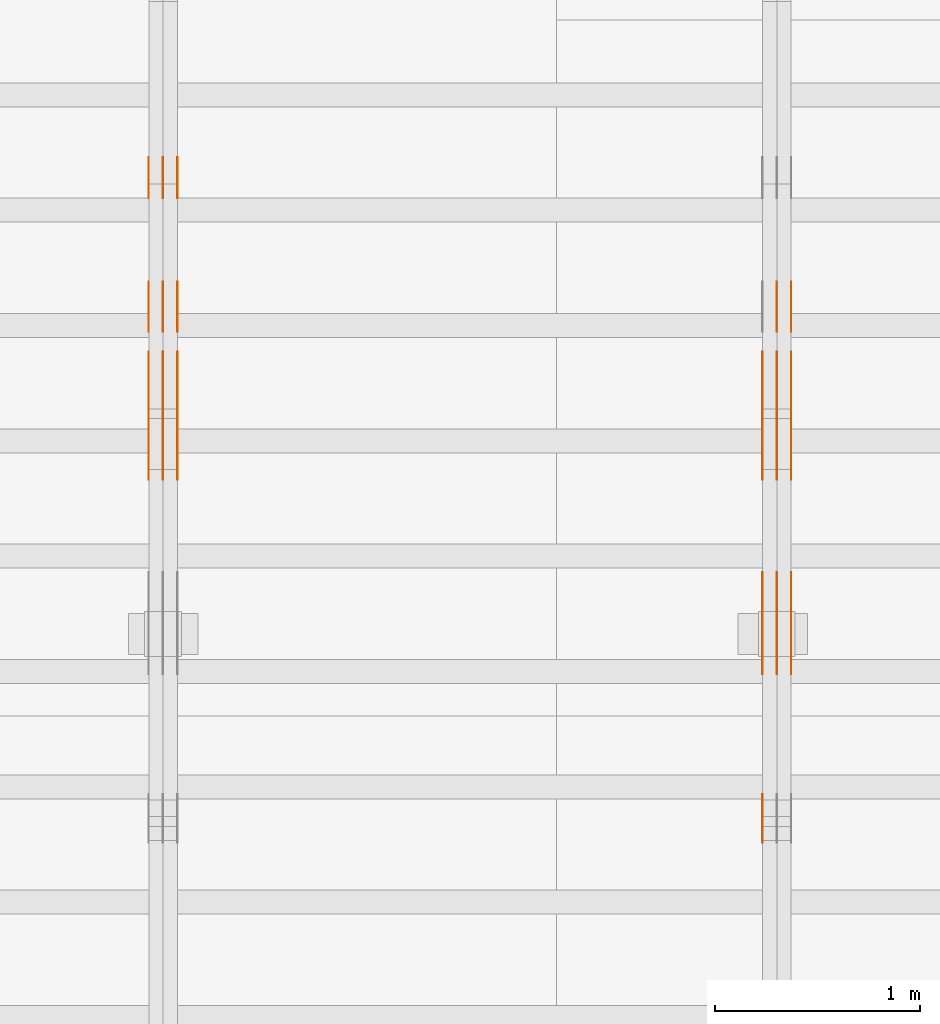
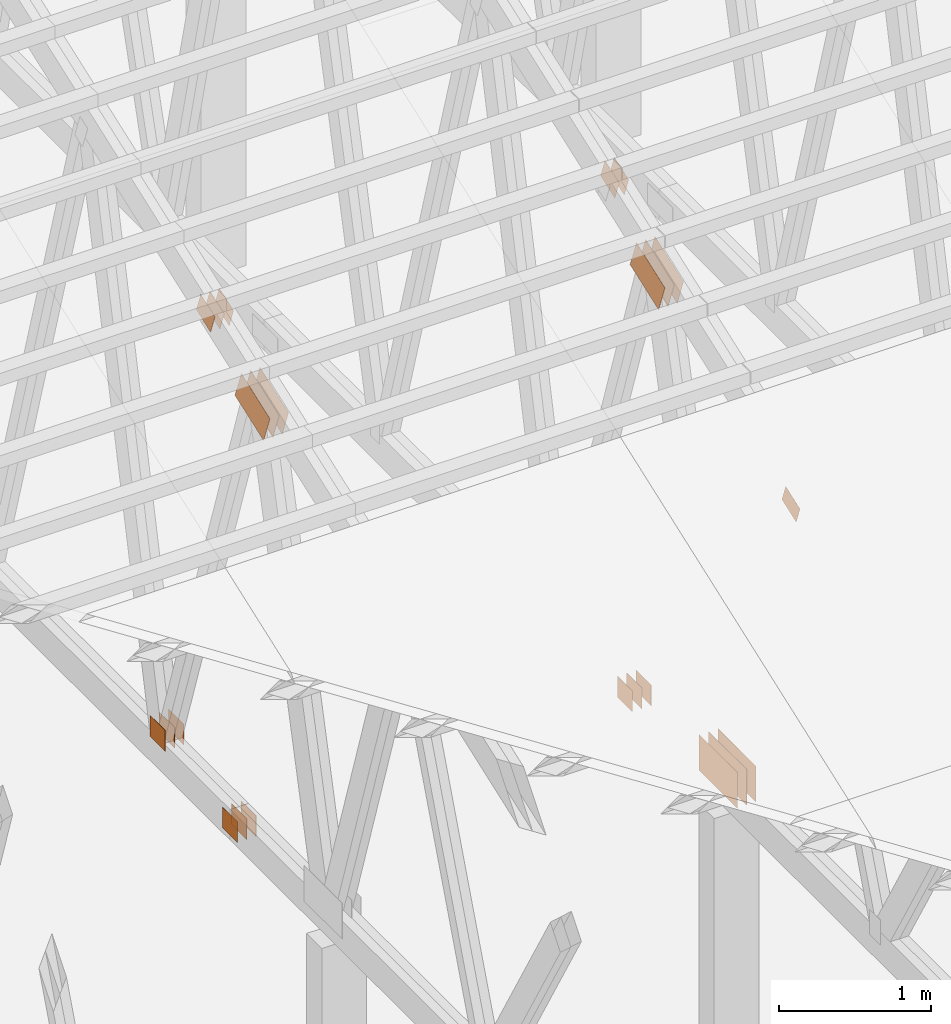
# One storey, part 101 of 189: 31 proxies.
"""IFC2X3 building model written with IfcOpenShell, lengths in millimetres."""

from ifc_helpers import new_model, entity, si_unit, converted_unit, derived_unit, direction, frame, frame_2d, origin, origin_2d_with_axis, place, context, subcontext, project, spatial, polyline, rectangle, outline, extrude, source, transform, mapped, material, type_object, type_shapes, element, save


model = new_model("IFC2X3")

# Units and contexts
model_context = context("Model", 3, precision=0.01, world=origin(), true_north=direction((6.12303176911189e-17, 1.0)))
body_context = subcontext(model_context, "Body", "Model", "MODEL_VIEW")
ifc_project = project(units=[si_unit("LENGTHUNIT", "METRE", prefix="MILLI"), si_unit("AREAUNIT", "SQUARE_METRE"), si_unit("VOLUMEUNIT", "CUBIC_METRE"), converted_unit("PLANEANGLEUNIT", "DEGREE", entity("IfcRatioMeasure", 0.0174532925199433), si_unit("PLANEANGLEUNIT", "RADIAN"), dimensions=[0, 0, 0, 0, 0, 0, 0]), si_unit("MASSUNIT", "GRAM", prefix="KILO"), derived_unit("MASSDENSITYUNIT", [(si_unit("MASSUNIT", "GRAM", prefix="KILO"), 1), (si_unit("LENGTHUNIT", "METRE"), -3)]), si_unit("TIMEUNIT", "SECOND"), si_unit("FREQUENCYUNIT", "HERTZ"), si_unit("THERMODYNAMICTEMPERATUREUNIT", "DEGREE_CELSIUS"), derived_unit("THERMALTRANSMITTANCEUNIT", [(si_unit("MASSUNIT", "GRAM", prefix="KILO"), 1), (si_unit("THERMODYNAMICTEMPERATUREUNIT", "KELVIN"), -1), (si_unit("TIMEUNIT", "SECOND"), -3)]), derived_unit("VOLUMETRICFLOWRATEUNIT", [(si_unit("LENGTHUNIT", "METRE"), 3), (si_unit("TIMEUNIT", "SECOND"), -1)]), si_unit("ELECTRICCURRENTUNIT", "AMPERE"), si_unit("ELECTRICVOLTAGEUNIT", "VOLT"), si_unit("POWERUNIT", "WATT"), si_unit("FORCEUNIT", "NEWTON"), si_unit("ILLUMINANCEUNIT", "LUX"), si_unit("LUMINOUSFLUXUNIT", "LUMEN"), si_unit("LUMINOUSINTENSITYUNIT", "CANDELA"), derived_unit("USERDEFINED", [(si_unit("MASSUNIT", "GRAM", prefix="KILO"), -1), (si_unit("LENGTHUNIT", "METRE"), -2), (si_unit("TIMEUNIT", "SECOND"), 3), (si_unit("LUMINOUSFLUXUNIT", "LUMEN"), 1)]), derived_unit("LINEARVELOCITYUNIT", [(si_unit("LENGTHUNIT", "METRE"), 1), (si_unit("TIMEUNIT", "SECOND"), -1)]), si_unit("PRESSUREUNIT", "PASCAL"), derived_unit("USERDEFINED", [(si_unit("LENGTHUNIT", "METRE"), -2), (si_unit("MASSUNIT", "GRAM", prefix="KILO"), 1), (si_unit("TIMEUNIT", "SECOND"), -2)])], contexts=[model_context])

# Site, building, storey
site_placement = place(None, origin())
site = spatial("IfcSite", under=ifc_project, at=site_placement, CompositionType="ELEMENT")
building_placement = place(site_placement, origin())
building = spatial("IfcBuilding", under=site, at=building_placement, CompositionType="ELEMENT")
storey_placement = place(building_placement, origin())
storey = spatial("IfcBuildingStorey", under=building, at=storey_placement, Name="Default", CompositionType="ELEMENT", Elevation=0.0)

# Proxies
ifc_material_1 = material(Name="IfcSurfaceStyle #171462")
building_element_proxy_type_1 = type_object("IfcBuildingElementProxyType", PredefinedType="NOTDEFINED", material=ifc_material_1)
shared_shape_1 = source(origin(), body_context, "Body", "SweptSolid", [
    extrude(outline(polyline([(-199.999582244654, -119.99984375717), (200.000344770932, -119.99984375717), (199.999582244655, 119.99984375717), (-200.000344770934, 119.99984375717), (-199.999582244654, -119.99984375717)])), frame((200.000344770932, 120.0000091947, 0.0), z_axis=(0.0, 0.0, 1.0), x_axis=(-1.0, 0.0, 0.0)), (0.0, 0.0, 1.0), 1.29999999999999),
])
type_shapes(building_element_proxy_type_1, [shared_shape_1])
proxy_1_placement = place(building_placement, frame((30301.3, 9961.90704972973, 3612.2451494258), z_axis=(-1.0, 0.0, 0.0), x_axis=(0.0, -0.939692620785908, -0.342020143325669)))
element("IfcBuildingElementProxy", 1, at=proxy_1_placement, inside=storey, type_object=building_element_proxy_type_1, material=ifc_material_1, context=body_context, shape_type="MappedRepresentation", body=[
    mapped(shared_shape_1, transform((0.0, 0.0, 0.0), scale=1.0)),
])
ifc_material_2 = material(Name="IfcSurfaceStyle #171405")
building_element_proxy_type_2 = type_object("IfcBuildingElementProxyType", PredefinedType="NOTDEFINED", material=ifc_material_2)
shared_shape_2 = source(origin(), body_context, "Body", "SweptSolid", [
    extrude(outline(polyline([(-199.999582244654, -119.99984375717), (200.000344770932, -119.99984375717), (199.999582244655, 119.99984375717), (-200.000344770934, 119.99984375717), (-199.999582244654, -119.99984375717)])), frame((200.000344770932, 120.0000091947, 0.0), z_axis=(0.0, 0.0, 1.0), x_axis=(-1.0, 0.0, 0.0)), (0.0, 0.0, 1.0), 1.29999999999997),
])
type_shapes(building_element_proxy_type_2, [shared_shape_2])
proxy_2_placement = place(building_placement, frame((30230.0, 9961.90704972973, 3612.2451494258), z_axis=(-1.0, 0.0, 0.0), x_axis=(0.0, -0.939692620785908, -0.342020143325669)))
element("IfcBuildingElementProxy", 2, at=proxy_2_placement, inside=storey, type_object=building_element_proxy_type_2, material=ifc_material_2, context=body_context, shape_type="MappedRepresentation", body=[
    mapped(shared_shape_2, transform((0.0, 0.0, 0.0), scale=1.0)),
])
ifc_material_3 = material(Name="IfcSurfaceStyle #171348")
building_element_proxy_type_3 = type_object("IfcBuildingElementProxyType", PredefinedType="NOTDEFINED", material=ifc_material_3)
shared_shape_3 = source(origin(), body_context, "Body", "SweptSolid", [
    extrude(outline(polyline([(-199.999582244654, -119.99984375717), (200.000344770932, -119.99984375717), (199.999582244655, 119.99984375717), (-200.000344770934, 119.99984375717), (-199.999582244654, -119.99984375717)])), frame((200.000344770932, 120.0000091947, 0.0), z_axis=(0.0, 0.0, 1.0), x_axis=(-1.0, 0.0, 0.0)), (0.0, 0.0, 1.0), 1.29999999999997),
])
type_shapes(building_element_proxy_type_3, [shared_shape_3])
proxy_3_placement = place(building_placement, frame((30231.3, 9961.90704972973, 3612.2451494258), z_axis=(-1.0, 0.0, 0.0), x_axis=(0.0, -0.939692620785908, -0.342020143325669)))
element("IfcBuildingElementProxy", 3, at=proxy_3_placement, inside=storey, type_object=building_element_proxy_type_3, material=ifc_material_3, context=body_context, shape_type="MappedRepresentation", body=[
    mapped(shared_shape_3, transform((0.0, 0.0, 0.0), scale=1.0)),
])
ifc_material_4 = material(Name="IfcSurfaceStyle #171291")
building_element_proxy_type_4 = type_object("IfcBuildingElementProxyType", PredefinedType="NOTDEFINED", material=ifc_material_4)
shared_shape_4 = source(origin(), body_context, "Body", "SweptSolid", [
    extrude(outline(polyline([(-199.999582244654, -119.99984375717), (200.000344770932, -119.99984375717), (199.999582244655, 119.99984375717), (-200.000344770934, 119.99984375717), (-199.999582244654, -119.99984375717)])), frame((200.000344770932, 120.0000091947, 0.0), z_axis=(0.0, 0.0, 1.0), x_axis=(-1.0, 0.0, 0.0)), (0.0, 0.0, 1.0), 1.29999999999998),
])
type_shapes(building_element_proxy_type_4, [shared_shape_4])
proxy_4_placement = place(building_placement, frame((30160.0, 9961.90704972973, 3612.2451494258), z_axis=(-1.0, 0.0, 0.0), x_axis=(0.0, -0.939692620785908, -0.342020143325669)))
element("IfcBuildingElementProxy", 4, at=proxy_4_placement, inside=storey, type_object=building_element_proxy_type_4, material=ifc_material_4, context=body_context, shape_type="MappedRepresentation", body=[
    mapped(shared_shape_4, transform((0.0, 0.0, 0.0), scale=1.0)),
])
ifc_material_5 = material(Name="IfcSurfaceStyle #170778")
building_element_proxy_type_5 = type_object("IfcBuildingElementProxyType", PredefinedType="NOTDEFINED", material=ifc_material_5)
shared_shape_5 = source(origin(), body_context, "Body", "SweptSolid", [
    extrude(rectangle(XDim=500.0, YDim=288.0, at=frame_2d((0.0, 1.4210854715202e-14), x_axis=(1.0, 0.0))), frame((250.000973740011, 144.0, 0.0), z_axis=(0.0, 0.0, 1.0), x_axis=(-1.0, 0.0, 0.0)), (0.0, 0.0, 1.0), 1.29999999999998),
])
type_shapes(building_element_proxy_type_5, [shared_shape_5])
proxy_5_placement = place(building_placement, frame((30301.3, 8551.90918250999, 389.0), z_axis=(-1.0, 0.0, 0.0), x_axis=(0.0, 1.0, 0.0)))
element("IfcBuildingElementProxy", 5, at=proxy_5_placement, inside=storey, type_object=building_element_proxy_type_5, material=ifc_material_5, context=body_context, shape_type="MappedRepresentation", body=[
    mapped(shared_shape_5, transform((0.0, 0.0, 0.0), scale=1.0)),
])
ifc_material_6 = material(Name="IfcSurfaceStyle #170721")
building_element_proxy_type_6 = type_object("IfcBuildingElementProxyType", PredefinedType="NOTDEFINED", material=ifc_material_6)
shared_shape_6 = source(origin(), body_context, "Body", "SweptSolid", [
    extrude(rectangle(XDim=500.0, YDim=288.0, at=frame_2d((0.0, 1.4210854715202e-14), x_axis=(1.0, 0.0))), frame((250.000973740011, 144.0, 0.0), z_axis=(0.0, 0.0, 1.0), x_axis=(-1.0, 0.0, 0.0)), (0.0, 0.0, 1.0), 1.29999999999997),
])
type_shapes(building_element_proxy_type_6, [shared_shape_6])
proxy_6_placement = place(building_placement, frame((30230.0, 8551.90918250999, 389.0), z_axis=(-1.0, 0.0, 0.0), x_axis=(0.0, 1.0, 0.0)))
element("IfcBuildingElementProxy", 6, at=proxy_6_placement, inside=storey, type_object=building_element_proxy_type_6, material=ifc_material_6, context=body_context, shape_type="MappedRepresentation", body=[
    mapped(shared_shape_6, transform((0.0, 0.0, 0.0), scale=1.0)),
])
ifc_material_7 = material(Name="IfcSurfaceStyle #170664")
building_element_proxy_type_7 = type_object("IfcBuildingElementProxyType", PredefinedType="NOTDEFINED", material=ifc_material_7)
shared_shape_7 = source(origin(), body_context, "Body", "SweptSolid", [
    extrude(rectangle(XDim=500.0, YDim=288.0, at=frame_2d((0.0, 1.4210854715202e-14), x_axis=(1.0, 0.0))), frame((250.000973740011, 144.0, 0.0), z_axis=(0.0, 0.0, 1.0), x_axis=(-1.0, 0.0, 0.0)), (0.0, 0.0, 1.0), 1.29999999999997),
])
type_shapes(building_element_proxy_type_7, [shared_shape_7])
proxy_7_placement = place(building_placement, frame((30231.3, 8551.90918250999, 389.0), z_axis=(-1.0, 0.0, 0.0), x_axis=(0.0, 1.0, 0.0)))
element("IfcBuildingElementProxy", 7, at=proxy_7_placement, inside=storey, type_object=building_element_proxy_type_7, material=ifc_material_7, context=body_context, shape_type="MappedRepresentation", body=[
    mapped(shared_shape_7, transform((0.0, 0.0, 0.0), scale=1.0)),
])
ifc_material_8 = material(Name="IfcSurfaceStyle #170607")
building_element_proxy_type_8 = type_object("IfcBuildingElementProxyType", PredefinedType="NOTDEFINED", material=ifc_material_8)
shared_shape_8 = source(origin(), body_context, "Body", "SweptSolid", [
    extrude(rectangle(XDim=500.0, YDim=288.0, at=frame_2d((0.0, 1.4210854715202e-14), x_axis=(1.0, 0.0))), frame((250.000973740011, 144.0, 0.0), z_axis=(0.0, 0.0, 1.0), x_axis=(-1.0, 0.0, 0.0)), (0.0, 0.0, 1.0), 1.29999999999997),
])
type_shapes(building_element_proxy_type_8, [shared_shape_8])
proxy_8_placement = place(building_placement, frame((30160.0, 8551.90918250999, 389.0), z_axis=(-1.0, 0.0, 0.0), x_axis=(0.0, 1.0, 0.0)))
element("IfcBuildingElementProxy", 8, at=proxy_8_placement, inside=storey, type_object=building_element_proxy_type_8, material=ifc_material_8, context=body_context, shape_type="MappedRepresentation", body=[
    mapped(shared_shape_8, transform((0.0, 0.0, 0.0), scale=1.0)),
])
ifc_material_9 = material(Name="IfcSurfaceStyle #170379")
building_element_proxy_type_9 = type_object("IfcBuildingElementProxyType", PredefinedType="NOTDEFINED", material=ifc_material_9)
shared_shape_9 = source(origin(), body_context, "Body", "SweptSolid", [
    extrude(outline(polyline([(-100.00048713087, -72.0000025659129), (100.000394045495, -72.0000025659129), (99.9995694622958, 72.0000025659129), (-99.9994763769209, 72.0000025659128), (-100.00048713087, -72.0000025659129)])), frame((100.000394045495, 72.0000025659128, 0.0), z_axis=(0.0, 0.0, 1.0), x_axis=(-1.0, 0.0, 0.0)), (0.0, 0.0, 1.0), 1.29999999999999),
])
type_shapes(building_element_proxy_type_9, [shared_shape_9])
proxy_9_placement = place(building_placement, frame((30160.0, 7965.16887114408, 2936.19963864386), z_axis=(-1.0, 0.0, 0.0), x_axis=(0.0, -0.939692620785908, -0.342020143325669)))
element("IfcBuildingElementProxy", 9, at=proxy_9_placement, inside=storey, type_object=building_element_proxy_type_9, material=ifc_material_9, context=body_context, shape_type="MappedRepresentation", body=[
    mapped(shared_shape_9, transform((0.0, 0.0, 0.0), scale=1.0)),
])
ifc_material_10 = material(Name="IfcSurfaceStyle #165138")
building_element_proxy_type_10 = type_object("IfcBuildingElementProxyType", PredefinedType="NOTDEFINED", material=ifc_material_10)
shared_shape_10 = source(origin(), body_context, "Body", "SweptSolid", [
    extrude(rectangle(XDim=200.0, YDim=168.0, at=origin_2d_with_axis()), frame((100.0, 84.0, 0.0), z_axis=(0.0, 0.0, 1.0), x_axis=(-1.0, 0.0, 0.0)), (0.0, 0.0, 1.0), 1.3),
])
type_shapes(building_element_proxy_type_10, [shared_shape_10])
proxy_10_placement = place(building_placement, frame((30301.3, 9929.23046875, 206.5), z_axis=(-1.0, 0.0, 0.0), x_axis=(0.0, 1.0, 0.0)))
element("IfcBuildingElementProxy", 10, at=proxy_10_placement, inside=storey, type_object=building_element_proxy_type_10, material=ifc_material_10, context=body_context, shape_type="MappedRepresentation", body=[
    mapped(shared_shape_10, transform((0.0, 0.0, 0.0), scale=1.0)),
])
ifc_material_11 = material(Name="IfcSurfaceStyle #165081")
building_element_proxy_type_11 = type_object("IfcBuildingElementProxyType", PredefinedType="NOTDEFINED", material=ifc_material_11)
shared_shape_11 = source(origin(), body_context, "Body", "SweptSolid", [
    extrude(rectangle(XDim=200.0, YDim=168.0, at=origin_2d_with_axis()), frame((100.0, 84.0, 0.0), z_axis=(0.0, 0.0, 1.0), x_axis=(-1.0, 0.0, 0.0)), (0.0, 0.0, 1.0), 1.29999999999998),
])
type_shapes(building_element_proxy_type_11, [shared_shape_11])
proxy_11_placement = place(building_placement, frame((30230.0, 9929.23046875, 206.5), z_axis=(-1.0, 0.0, 0.0), x_axis=(0.0, 1.0, 0.0)))
element("IfcBuildingElementProxy", 11, at=proxy_11_placement, inside=storey, type_object=building_element_proxy_type_11, material=ifc_material_11, context=body_context, shape_type="MappedRepresentation", body=[
    mapped(shared_shape_11, transform((0.0, 0.0, 0.0), scale=1.0)),
])
ifc_material_12 = material(Name="IfcSurfaceStyle #165024")
building_element_proxy_type_12 = type_object("IfcBuildingElementProxyType", PredefinedType="NOTDEFINED", material=ifc_material_12)
shared_shape_12 = source(origin(), body_context, "Body", "SweptSolid", [
    extrude(rectangle(XDim=200.0, YDim=168.0, at=origin_2d_with_axis()), frame((100.0, 84.0, 0.0), z_axis=(0.0, 0.0, 1.0), x_axis=(-1.0, 0.0, 0.0)), (0.0, 0.0, 1.0), 1.29999999999998),
])
type_shapes(building_element_proxy_type_12, [shared_shape_12])
proxy_12_placement = place(building_placement, frame((30231.3, 9929.23046875, 206.5), z_axis=(-1.0, 0.0, 0.0), x_axis=(0.0, 1.0, 0.0)))
element("IfcBuildingElementProxy", 12, at=proxy_12_placement, inside=storey, type_object=building_element_proxy_type_12, material=ifc_material_12, context=body_context, shape_type="MappedRepresentation", body=[
    mapped(shared_shape_12, transform((0.0, 0.0, 0.0), scale=1.0)),
])
ifc_material_13 = material(Name="IfcSurfaceStyle #164967")
building_element_proxy_type_13 = type_object("IfcBuildingElementProxyType", PredefinedType="NOTDEFINED", material=ifc_material_13)
shared_shape_13 = source(origin(), body_context, "Body", "SweptSolid", [
    extrude(rectangle(XDim=200.0, YDim=168.0, at=origin_2d_with_axis()), frame((100.0, 84.0, 0.0), z_axis=(0.0, 0.0, 1.0), x_axis=(-1.0, 0.0, 0.0)), (0.0, 0.0, 1.0), 1.29999999999999),
])
type_shapes(building_element_proxy_type_13, [shared_shape_13])
proxy_13_placement = place(building_placement, frame((30160.0, 9929.23046875, 206.5), z_axis=(-1.0, 0.0, 0.0), x_axis=(0.0, 1.0, 0.0)))
element("IfcBuildingElementProxy", 13, at=proxy_13_placement, inside=storey, type_object=building_element_proxy_type_13, material=ifc_material_13, context=body_context, shape_type="MappedRepresentation", body=[
    mapped(shared_shape_13, transform((0.0, 0.0, 0.0), scale=1.0)),
])
ifc_material_14 = material(Name="IfcSurfaceStyle #164058")
building_element_proxy_type_14 = type_object("IfcBuildingElementProxyType", PredefinedType="NOTDEFINED", material=ifc_material_14)
shared_shape_14 = source(origin(), body_context, "Body", "SweptSolid", [
    extrude(outline(polyline([(-100.00072430513, -84.0000258989549), (100.000156871239, -84.0000258989549), (99.9997648860508, 84.0000258989549), (-99.9991974521591, 84.0000258989548), (-100.00072430513, -84.0000258989549)])), frame((100.000156871239, 84.0000258989548, 0.0), z_axis=(0.0, 0.0, 1.0), x_axis=(-1.0, 0.0, 0.0)), (0.0, 0.0, 1.0), 1.3),
])
type_shapes(building_element_proxy_type_14, [shared_shape_14])
proxy_14_placement = place(building_placement, frame((30301.3, 10226.4409888304, 4081.14941482552), z_axis=(-1.0, 0.0, 0.0), x_axis=(0.0, 0.939692620785908, 0.342020143325669)))
element("IfcBuildingElementProxy", 14, at=proxy_14_placement, inside=storey, type_object=building_element_proxy_type_14, material=ifc_material_14, context=body_context, shape_type="MappedRepresentation", body=[
    mapped(shared_shape_14, transform((0.0, 0.0, 0.0), scale=1.0)),
])
ifc_material_15 = material(Name="IfcSurfaceStyle #164001")
building_element_proxy_type_15 = type_object("IfcBuildingElementProxyType", PredefinedType="NOTDEFINED", material=ifc_material_15)
shared_shape_15 = source(origin(), body_context, "Body", "SweptSolid", [
    extrude(outline(polyline([(-100.00072430513, -84.0000258989549), (100.000156871239, -84.0000258989549), (99.9997648860508, 84.0000258989549), (-99.9991974521591, 84.0000258989548), (-100.00072430513, -84.0000258989549)])), frame((100.000156871239, 84.0000258989548, 0.0), z_axis=(0.0, 0.0, 1.0), x_axis=(-1.0, 0.0, 0.0)), (0.0, 0.0, 1.0), 1.29999999999998),
])
type_shapes(building_element_proxy_type_15, [shared_shape_15])
proxy_15_placement = place(building_placement, frame((30230.0, 10226.4409888304, 4081.14941482552), z_axis=(-1.0, 0.0, 0.0), x_axis=(0.0, 0.939692620785908, 0.342020143325669)))
element("IfcBuildingElementProxy", 15, at=proxy_15_placement, inside=storey, type_object=building_element_proxy_type_15, material=ifc_material_15, context=body_context, shape_type="MappedRepresentation", body=[
    mapped(shared_shape_15, transform((0.0, 0.0, 0.0), scale=1.0)),
])
ifc_material_16 = material(Name="IfcSurfaceStyle #155900")
building_element_proxy_type_16 = type_object("IfcBuildingElementProxyType", PredefinedType="NOTDEFINED", material=ifc_material_16)
shared_shape_16 = source(origin(), body_context, "Body", "SweptSolid", [
    extrude(rectangle(XDim=200.0, YDim=168.0, at=origin_2d_with_axis()), frame((100.000765376775, 84.0, 0.0), z_axis=(0.0, 0.0, 1.0), x_axis=(-1.0, 0.0, 0.0)), (0.0, 0.0, 1.0), 1.3),
])
type_shapes(building_element_proxy_type_16, [shared_shape_16])
proxy_16_placement = place(building_placement, frame((27301.3, 10880.1574377482, 365.0), z_axis=(-1.0, 0.0, 0.0), x_axis=(0.0, 1.0, 0.0)))
element("IfcBuildingElementProxy", 16, at=proxy_16_placement, inside=storey, type_object=building_element_proxy_type_16, material=ifc_material_16, context=body_context, shape_type="MappedRepresentation", body=[
    mapped(shared_shape_16, transform((0.0, 0.0, 0.0), scale=1.0)),
])
ifc_material_17 = material(Name="IfcSurfaceStyle #155843")
building_element_proxy_type_17 = type_object("IfcBuildingElementProxyType", PredefinedType="NOTDEFINED", material=ifc_material_17)
shared_shape_17 = source(origin(), body_context, "Body", "SweptSolid", [
    extrude(rectangle(XDim=200.0, YDim=168.0, at=origin_2d_with_axis()), frame((100.000765376775, 84.0, 0.0), z_axis=(0.0, 0.0, 1.0), x_axis=(-1.0, 0.0, 0.0)), (0.0, 0.0, 1.0), 1.29999999999998),
])
type_shapes(building_element_proxy_type_17, [shared_shape_17])
proxy_17_placement = place(building_placement, frame((27230.0, 10880.1574377482, 365.0), z_axis=(-1.0, 0.0, 0.0), x_axis=(0.0, 1.0, 0.0)))
element("IfcBuildingElementProxy", 17, at=proxy_17_placement, inside=storey, type_object=building_element_proxy_type_17, material=ifc_material_17, context=body_context, shape_type="MappedRepresentation", body=[
    mapped(shared_shape_17, transform((0.0, 0.0, 0.0), scale=1.0)),
])
ifc_material_18 = material(Name="IfcSurfaceStyle #155786")
building_element_proxy_type_18 = type_object("IfcBuildingElementProxyType", PredefinedType="NOTDEFINED", material=ifc_material_18)
shared_shape_18 = source(origin(), body_context, "Body", "SweptSolid", [
    extrude(rectangle(XDim=200.0, YDim=168.0, at=origin_2d_with_axis()), frame((100.000765376775, 84.0, 0.0), z_axis=(0.0, 0.0, 1.0), x_axis=(-1.0, 0.0, 0.0)), (0.0, 0.0, 1.0), 1.29999999999998),
])
type_shapes(building_element_proxy_type_18, [shared_shape_18])
proxy_18_placement = place(building_placement, frame((27231.3, 10880.1574377482, 365.0), z_axis=(-1.0, 0.0, 0.0), x_axis=(0.0, 1.0, 0.0)))
element("IfcBuildingElementProxy", 18, at=proxy_18_placement, inside=storey, type_object=building_element_proxy_type_18, material=ifc_material_18, context=body_context, shape_type="MappedRepresentation", body=[
    mapped(shared_shape_18, transform((0.0, 0.0, 0.0), scale=1.0)),
])
ifc_material_19 = material(Name="IfcSurfaceStyle #155729")
building_element_proxy_type_19 = type_object("IfcBuildingElementProxyType", PredefinedType="NOTDEFINED", material=ifc_material_19)
shared_shape_19 = source(origin(), body_context, "Body", "SweptSolid", [
    extrude(rectangle(XDim=200.0, YDim=168.0, at=origin_2d_with_axis()), frame((100.000765376775, 84.0, 0.0), z_axis=(0.0, 0.0, 1.0), x_axis=(-1.0, 0.0, 0.0)), (0.0, 0.0, 1.0), 1.29999999999999),
])
type_shapes(building_element_proxy_type_19, [shared_shape_19])
proxy_19_placement = place(building_placement, frame((27160.0, 10880.1574377482, 365.0), z_axis=(-1.0, 0.0, 0.0), x_axis=(0.0, 1.0, 0.0)))
element("IfcBuildingElementProxy", 19, at=proxy_19_placement, inside=storey, type_object=building_element_proxy_type_19, material=ifc_material_19, context=body_context, shape_type="MappedRepresentation", body=[
    mapped(shared_shape_19, transform((0.0, 0.0, 0.0), scale=1.0)),
])
ifc_material_20 = material(Name="IfcSurfaceStyle #155672")
building_element_proxy_type_20 = type_object("IfcBuildingElementProxyType", PredefinedType="NOTDEFINED", material=ifc_material_20)
shared_shape_20 = source(origin(), body_context, "Body", "SweptSolid", [
    extrude(outline(polyline([(-199.999582244654, -119.99984375717), (200.000344770932, -119.99984375717), (199.999582244655, 119.99984375717), (-200.000344770934, 119.99984375717), (-199.999582244654, -119.99984375717)])), frame((200.000344770932, 120.0000091947, 0.0), z_axis=(0.0, 0.0, 1.0), x_axis=(-1.0, 0.0, 0.0)), (0.0, 0.0, 1.0), 1.29999999999999),
])
type_shapes(building_element_proxy_type_20, [shared_shape_20])
proxy_20_placement = place(building_placement, frame((27301.3, 9961.90704972973, 3612.2451494258), z_axis=(-1.0, 0.0, 0.0), x_axis=(0.0, -0.939692620785908, -0.342020143325669)))
element("IfcBuildingElementProxy", 20, at=proxy_20_placement, inside=storey, type_object=building_element_proxy_type_20, material=ifc_material_20, context=body_context, shape_type="MappedRepresentation", body=[
    mapped(shared_shape_20, transform((0.0, 0.0, 0.0), scale=1.0)),
])
ifc_material_21 = material(Name="IfcSurfaceStyle #155615")
building_element_proxy_type_21 = type_object("IfcBuildingElementProxyType", PredefinedType="NOTDEFINED", material=ifc_material_21)
shared_shape_21 = source(origin(), body_context, "Body", "SweptSolid", [
    extrude(outline(polyline([(-199.999582244654, -119.99984375717), (200.000344770932, -119.99984375717), (199.999582244655, 119.99984375717), (-200.000344770934, 119.99984375717), (-199.999582244654, -119.99984375717)])), frame((200.000344770932, 120.0000091947, 0.0), z_axis=(0.0, 0.0, 1.0), x_axis=(-1.0, 0.0, 0.0)), (0.0, 0.0, 1.0), 1.29999999999997),
])
type_shapes(building_element_proxy_type_21, [shared_shape_21])
proxy_21_placement = place(building_placement, frame((27230.0, 9961.90704972973, 3612.2451494258), z_axis=(-1.0, 0.0, 0.0), x_axis=(0.0, -0.939692620785908, -0.342020143325669)))
element("IfcBuildingElementProxy", 21, at=proxy_21_placement, inside=storey, type_object=building_element_proxy_type_21, material=ifc_material_21, context=body_context, shape_type="MappedRepresentation", body=[
    mapped(shared_shape_21, transform((0.0, 0.0, 0.0), scale=1.0)),
])
ifc_material_22 = material(Name="IfcSurfaceStyle #155558")
building_element_proxy_type_22 = type_object("IfcBuildingElementProxyType", PredefinedType="NOTDEFINED", material=ifc_material_22)
shared_shape_22 = source(origin(), body_context, "Body", "SweptSolid", [
    extrude(outline(polyline([(-199.999582244654, -119.99984375717), (200.000344770932, -119.99984375717), (199.999582244655, 119.99984375717), (-200.000344770934, 119.99984375717), (-199.999582244654, -119.99984375717)])), frame((200.000344770932, 120.0000091947, 0.0), z_axis=(0.0, 0.0, 1.0), x_axis=(-1.0, 0.0, 0.0)), (0.0, 0.0, 1.0), 1.29999999999997),
])
type_shapes(building_element_proxy_type_22, [shared_shape_22])
proxy_22_placement = place(building_placement, frame((27231.3, 9961.90704972973, 3612.2451494258), z_axis=(-1.0, 0.0, 0.0), x_axis=(0.0, -0.939692620785908, -0.342020143325669)))
element("IfcBuildingElementProxy", 22, at=proxy_22_placement, inside=storey, type_object=building_element_proxy_type_22, material=ifc_material_22, context=body_context, shape_type="MappedRepresentation", body=[
    mapped(shared_shape_22, transform((0.0, 0.0, 0.0), scale=1.0)),
])
ifc_material_23 = material(Name="IfcSurfaceStyle #155501")
building_element_proxy_type_23 = type_object("IfcBuildingElementProxyType", PredefinedType="NOTDEFINED", material=ifc_material_23)
shared_shape_23 = source(origin(), body_context, "Body", "SweptSolid", [
    extrude(outline(polyline([(-199.999582244654, -119.99984375717), (200.000344770932, -119.99984375717), (199.999582244655, 119.99984375717), (-200.000344770934, 119.99984375717), (-199.999582244654, -119.99984375717)])), frame((200.000344770932, 120.0000091947, 0.0), z_axis=(0.0, 0.0, 1.0), x_axis=(-1.0, 0.0, 0.0)), (0.0, 0.0, 1.0), 1.29999999999998),
])
type_shapes(building_element_proxy_type_23, [shared_shape_23])
proxy_23_placement = place(building_placement, frame((27160.0, 9961.90704972973, 3612.2451494258), z_axis=(-1.0, 0.0, 0.0), x_axis=(0.0, -0.939692620785908, -0.342020143325669)))
element("IfcBuildingElementProxy", 23, at=proxy_23_placement, inside=storey, type_object=building_element_proxy_type_23, material=ifc_material_23, context=body_context, shape_type="MappedRepresentation", body=[
    mapped(shared_shape_23, transform((0.0, 0.0, 0.0), scale=1.0)),
])
ifc_material_24 = material(Name="IfcSurfaceStyle #149348")
building_element_proxy_type_24 = type_object("IfcBuildingElementProxyType", PredefinedType="NOTDEFINED", material=ifc_material_24)
shared_shape_24 = source(origin(), body_context, "Body", "SweptSolid", [
    extrude(rectangle(XDim=200.0, YDim=168.0, at=origin_2d_with_axis()), frame((100.0, 84.0, 0.0), z_axis=(0.0, 0.0, 1.0), x_axis=(-1.0, 0.0, 0.0)), (0.0, 0.0, 1.0), 1.3),
])
type_shapes(building_element_proxy_type_24, [shared_shape_24])
proxy_24_placement = place(building_placement, frame((27301.3, 9929.23046875, 206.5), z_axis=(-1.0, 0.0, 0.0), x_axis=(0.0, 1.0, 0.0)))
element("IfcBuildingElementProxy", 24, at=proxy_24_placement, inside=storey, type_object=building_element_proxy_type_24, material=ifc_material_24, context=body_context, shape_type="MappedRepresentation", body=[
    mapped(shared_shape_24, transform((0.0, 0.0, 0.0), scale=1.0)),
])
ifc_material_25 = material(Name="IfcSurfaceStyle #149291")
building_element_proxy_type_25 = type_object("IfcBuildingElementProxyType", PredefinedType="NOTDEFINED", material=ifc_material_25)
shared_shape_25 = source(origin(), body_context, "Body", "SweptSolid", [
    extrude(rectangle(XDim=200.0, YDim=168.0, at=origin_2d_with_axis()), frame((100.0, 84.0, 0.0), z_axis=(0.0, 0.0, 1.0), x_axis=(-1.0, 0.0, 0.0)), (0.0, 0.0, 1.0), 1.29999999999998),
])
type_shapes(building_element_proxy_type_25, [shared_shape_25])
proxy_25_placement = place(building_placement, frame((27230.0, 9929.23046875, 206.5), z_axis=(-1.0, 0.0, 0.0), x_axis=(0.0, 1.0, 0.0)))
element("IfcBuildingElementProxy", 25, at=proxy_25_placement, inside=storey, type_object=building_element_proxy_type_25, material=ifc_material_25, context=body_context, shape_type="MappedRepresentation", body=[
    mapped(shared_shape_25, transform((0.0, 0.0, 0.0), scale=1.0)),
])
ifc_material_26 = material(Name="IfcSurfaceStyle #149234")
building_element_proxy_type_26 = type_object("IfcBuildingElementProxyType", PredefinedType="NOTDEFINED", material=ifc_material_26)
shared_shape_26 = source(origin(), body_context, "Body", "SweptSolid", [
    extrude(rectangle(XDim=200.0, YDim=168.0, at=origin_2d_with_axis()), frame((100.0, 84.0, 0.0), z_axis=(0.0, 0.0, 1.0), x_axis=(-1.0, 0.0, 0.0)), (0.0, 0.0, 1.0), 1.29999999999998),
])
type_shapes(building_element_proxy_type_26, [shared_shape_26])
proxy_26_placement = place(building_placement, frame((27231.3, 9929.23046875, 206.5), z_axis=(-1.0, 0.0, 0.0), x_axis=(0.0, 1.0, 0.0)))
element("IfcBuildingElementProxy", 26, at=proxy_26_placement, inside=storey, type_object=building_element_proxy_type_26, material=ifc_material_26, context=body_context, shape_type="MappedRepresentation", body=[
    mapped(shared_shape_26, transform((0.0, 0.0, 0.0), scale=1.0)),
])
ifc_material_27 = material(Name="IfcSurfaceStyle #149177")
building_element_proxy_type_27 = type_object("IfcBuildingElementProxyType", PredefinedType="NOTDEFINED", material=ifc_material_27)
shared_shape_27 = source(origin(), body_context, "Body", "SweptSolid", [
    extrude(rectangle(XDim=200.0, YDim=168.0, at=origin_2d_with_axis()), frame((100.0, 84.0, 0.0), z_axis=(0.0, 0.0, 1.0), x_axis=(-1.0, 0.0, 0.0)), (0.0, 0.0, 1.0), 1.29999999999999),
])
type_shapes(building_element_proxy_type_27, [shared_shape_27])
proxy_27_placement = place(building_placement, frame((27160.0, 9929.23046875, 206.5), z_axis=(-1.0, 0.0, 0.0), x_axis=(0.0, 1.0, 0.0)))
element("IfcBuildingElementProxy", 27, at=proxy_27_placement, inside=storey, type_object=building_element_proxy_type_27, material=ifc_material_27, context=body_context, shape_type="MappedRepresentation", body=[
    mapped(shared_shape_27, transform((0.0, 0.0, 0.0), scale=1.0)),
])
ifc_material_28 = material(Name="IfcSurfaceStyle #148268")
building_element_proxy_type_28 = type_object("IfcBuildingElementProxyType", PredefinedType="NOTDEFINED", material=ifc_material_28)
shared_shape_28 = source(origin(), body_context, "Body", "SweptSolid", [
    extrude(outline(polyline([(-100.00072430513, -84.0000258989549), (100.000156871239, -84.0000258989549), (99.9997648860508, 84.0000258989549), (-99.9991974521591, 84.0000258989548), (-100.00072430513, -84.0000258989549)])), frame((100.000156871239, 84.0000258989548, 0.0), z_axis=(0.0, 0.0, 1.0), x_axis=(-1.0, 0.0, 0.0)), (0.0, 0.0, 1.0), 1.3),
])
type_shapes(building_element_proxy_type_28, [shared_shape_28])
proxy_28_placement = place(building_placement, frame((27301.3, 10226.4409888304, 4081.14941482552), z_axis=(-1.0, 0.0, 0.0), x_axis=(0.0, 0.939692620785908, 0.342020143325669)))
element("IfcBuildingElementProxy", 28, at=proxy_28_placement, inside=storey, type_object=building_element_proxy_type_28, material=ifc_material_28, context=body_context, shape_type="MappedRepresentation", body=[
    mapped(shared_shape_28, transform((0.0, 0.0, 0.0), scale=1.0)),
])
ifc_material_29 = material(Name="IfcSurfaceStyle #148211")
building_element_proxy_type_29 = type_object("IfcBuildingElementProxyType", PredefinedType="NOTDEFINED", material=ifc_material_29)
shared_shape_29 = source(origin(), body_context, "Body", "SweptSolid", [
    extrude(outline(polyline([(-100.00072430513, -84.0000258989549), (100.000156871239, -84.0000258989549), (99.9997648860508, 84.0000258989549), (-99.9991974521591, 84.0000258989548), (-100.00072430513, -84.0000258989549)])), frame((100.000156871239, 84.0000258989548, 0.0), z_axis=(0.0, 0.0, 1.0), x_axis=(-1.0, 0.0, 0.0)), (0.0, 0.0, 1.0), 1.29999999999998),
])
type_shapes(building_element_proxy_type_29, [shared_shape_29])
proxy_29_placement = place(building_placement, frame((27230.0, 10226.4409888304, 4081.14941482552), z_axis=(-1.0, 0.0, 0.0), x_axis=(0.0, 0.939692620785908, 0.342020143325669)))
element("IfcBuildingElementProxy", 29, at=proxy_29_placement, inside=storey, type_object=building_element_proxy_type_29, material=ifc_material_29, context=body_context, shape_type="MappedRepresentation", body=[
    mapped(shared_shape_29, transform((0.0, 0.0, 0.0), scale=1.0)),
])
ifc_material_30 = material(Name="IfcSurfaceStyle #148154")
building_element_proxy_type_30 = type_object("IfcBuildingElementProxyType", PredefinedType="NOTDEFINED", material=ifc_material_30)
shared_shape_30 = source(origin(), body_context, "Body", "SweptSolid", [
    extrude(outline(polyline([(-100.00072430513, -84.0000258989549), (100.000156871239, -84.0000258989549), (99.9997648860508, 84.0000258989549), (-99.9991974521591, 84.0000258989548), (-100.00072430513, -84.0000258989549)])), frame((100.000156871239, 84.0000258989548, 0.0), z_axis=(0.0, 0.0, 1.0), x_axis=(-1.0, 0.0, 0.0)), (0.0, 0.0, 1.0), 1.29999999999998),
])
type_shapes(building_element_proxy_type_30, [shared_shape_30])
proxy_30_placement = place(building_placement, frame((27231.3, 10226.4409888304, 4081.14941482552), z_axis=(-1.0, 0.0, 0.0), x_axis=(0.0, 0.939692620785908, 0.342020143325669)))
element("IfcBuildingElementProxy", 30, at=proxy_30_placement, inside=storey, type_object=building_element_proxy_type_30, material=ifc_material_30, context=body_context, shape_type="MappedRepresentation", body=[
    mapped(shared_shape_30, transform((0.0, 0.0, 0.0), scale=1.0)),
])
ifc_material_31 = material(Name="IfcSurfaceStyle #148097")
building_element_proxy_type_31 = type_object("IfcBuildingElementProxyType", PredefinedType="NOTDEFINED", material=ifc_material_31)
shared_shape_31 = source(origin(), body_context, "Body", "SweptSolid", [
    extrude(outline(polyline([(-100.00072430513, -84.0000258989549), (100.000156871239, -84.0000258989549), (99.9997648860508, 84.0000258989549), (-99.9991974521591, 84.0000258989548), (-100.00072430513, -84.0000258989549)])), frame((100.000156871239, 84.0000258989548, 0.0), z_axis=(0.0, 0.0, 1.0), x_axis=(-1.0, 0.0, 0.0)), (0.0, 0.0, 1.0), 1.29999999999999),
])
type_shapes(building_element_proxy_type_31, [shared_shape_31])
proxy_31_placement = place(building_placement, frame((27160.0, 10226.4409888304, 4081.14941482552), z_axis=(-1.0, 0.0, 0.0), x_axis=(0.0, 0.939692620785908, 0.342020143325669)))
element("IfcBuildingElementProxy", 31, at=proxy_31_placement, inside=storey, type_object=building_element_proxy_type_31, material=ifc_material_31, context=body_context, shape_type="MappedRepresentation", body=[
    mapped(shared_shape_31, transform((0.0, 0.0, 0.0), scale=1.0)),
])

save(model, "model.ifc")
